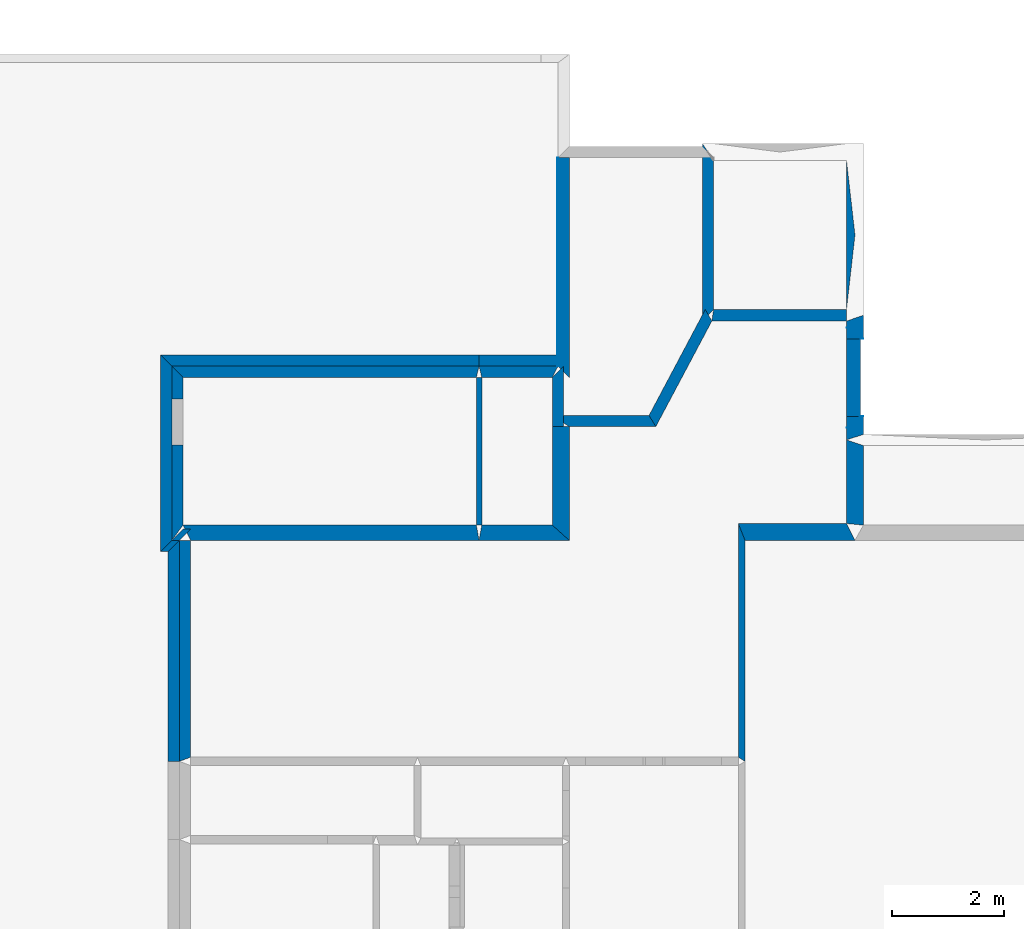
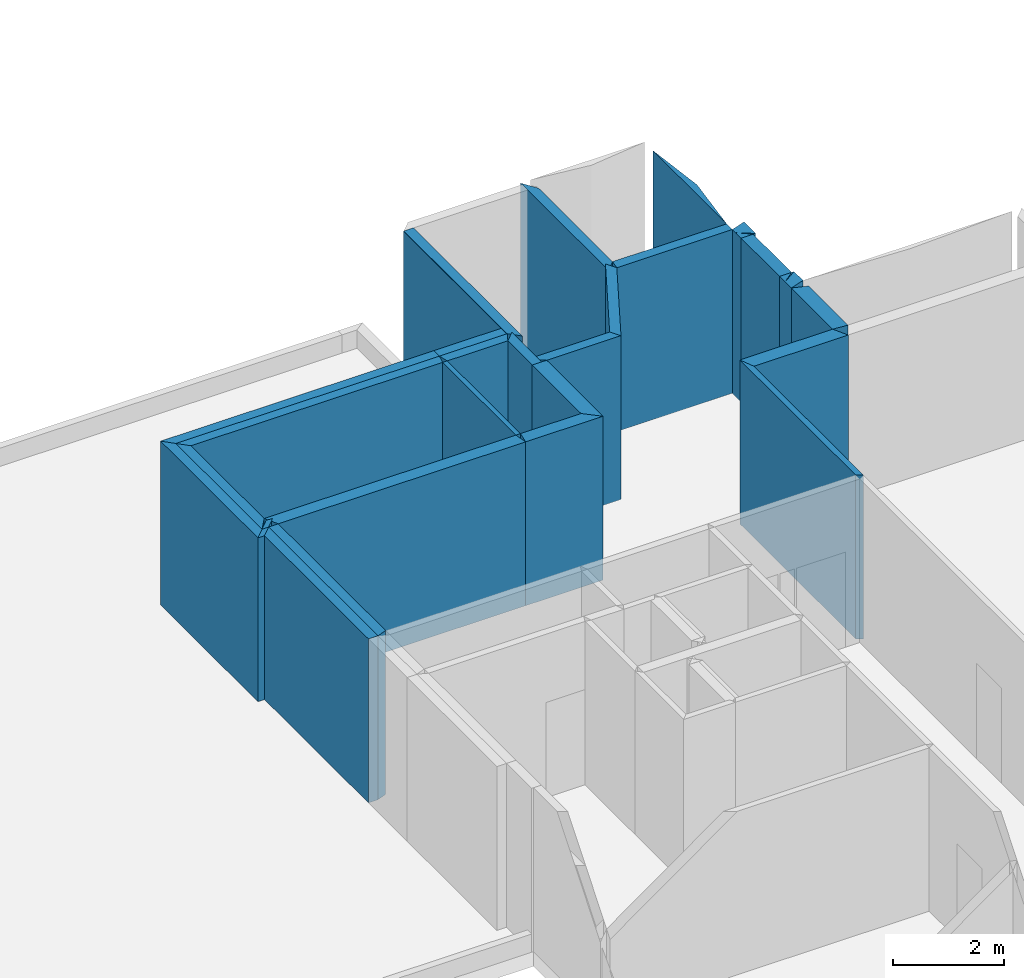
# One storey, part 4 of 72: 30 walls, 1 opening.
"""IFC2X3 building model written with IfcOpenShell, lengths in metres."""

from ifc_helpers import new_model, entity, si_unit, converted_unit, derived_unit, frame, origin_with_axes, place, context, project, spatial, polyline, outline, extrude, material, layer, layer_set, layer_usage, element, save


model = new_model("IFC2X3")

# Units and contexts
context_of_model_1 = context(None, 3, world=origin_with_axes())
context_of_model_2 = context(None, 3, world=origin_with_axes())
context_of_model_3 = context(None, 2, world=origin_with_axes())
context_of_model_4 = context(None, 3, world=origin_with_axes())
ifc_project = project(units=[si_unit("LENGTHUNIT", "METRE"), si_unit("AREAUNIT", "SQUARE_METRE"), si_unit("ELECTRICCURRENTUNIT", "AMPERE"), si_unit("ELECTRICVOLTAGEUNIT", "VOLT"), si_unit("ELECTRICRESISTANCEUNIT", "OHM"), si_unit("POWERUNIT", "WATT"), si_unit("MASSUNIT", "GRAM"), si_unit("SOLIDANGLEUNIT", "STERADIAN"), si_unit("THERMODYNAMICTEMPERATUREUNIT", "KELVIN"), si_unit("PRESSUREUNIT", "PASCAL"), si_unit("LUMINOUSFLUXUNIT", "LUMEN"), si_unit("ILLUMINANCEUNIT", "LUX"), si_unit("FREQUENCYUNIT", "HERTZ"), si_unit("VOLUMEUNIT", "CUBIC_METRE"), si_unit("TIMEUNIT", "SECOND"), derived_unit("VOLUMETRICFLOWRATEUNIT", [(si_unit("TIMEUNIT", "SECOND"), -1), (si_unit("VOLUMEUNIT", "CUBIC_METRE"), 1)]), derived_unit("THERMALTRANSMITTANCEUNIT", [(si_unit("AREAUNIT", "SQUARE_METRE"), -1), (si_unit("THERMODYNAMICTEMPERATUREUNIT", "KELVIN"), -1), (si_unit("POWERUNIT", "WATT"), 1)]), converted_unit("PLANEANGLEUNIT", "DEGREE", entity("IfcPlaneAngleMeasure", 57.29577951308232), si_unit("PLANEANGLEUNIT", "RADIAN"), dimensions=[0, 0, 0, 0, 0, 0, 0])], contexts=[context_of_model_1, context_of_model_2, context_of_model_3, context_of_model_4])

# Site, building, storey
site = spatial("IfcSite", under=ifc_project, CompositionType="ELEMENT")
building_placement = place(None, origin_with_axes())
building = spatial("IfcBuilding", under=site, at=building_placement, Name="200", CompositionType="ELEMENT")
storey_placement = place(building_placement, frame((0.0, 0.0, 15.68000030517578), z_axis=(0.0, 0.0, 1.0), x_axis=(1.0, 0.0, 0.0)))
storey = spatial("IfcBuildingStorey", under=building, at=storey_placement, Name="3.etasje", CompositionType="ELEMENT", Elevation=15.68000030517578)

# Walls
ifc_material_1 = material(Name="Layer-YV04 20 cm")
ifc_layer_1 = layer(ifc_material_1, 0.2000000029802322, ventilated=False)
ifc_layer_set_1 = layer_set([ifc_layer_1])
ifc_layer_usage_1 = layer_usage(ifc_layer_set_1, "AXIS2", "POSITIVE", 0.0)
wall_1_placement = place(storey_placement, frame((5.74828577041626, 48.1895751953125, 0.0), z_axis=(0.0, 0.0, 1.0), x_axis=(-1.0, -8.742277657347586e-08, 0.0)))
element("IfcWallStandardCase", 1, at=wall_1_placement, inside=storey, material=ifc_layer_usage_1, Name="YV04 20 cm", context=context_of_model_1, shape_type="SweptSolid", body=[
    extrude(outline(polyline([(0.0, 0.0), (0.05150032043457052, 0.0), (0.3015003204345584, 0.2000007629394664), (0.3015003204345584, 0.2000007629394664), (0.0, 0.0)])), frame((0.0, 0.0, 0.0), z_axis=(0.0, 0.0, 1.0), x_axis=(0.9999999999999961, -8.742284065731986e-08, 0.0)), (0.0, 0.0, 1.0), 3.6),
])
wall_2_placement = place(storey_placement, frame((5.69678544998169, 49.57145309448242, 0.0), z_axis=(0.0, 0.0, 1.0), x_axis=(1.0, 0.0, 0.0)))
element("IfcWallStandardCase", 2, at=wall_2_placement, inside=storey, material=ifc_layer_usage_1, Name="YV04 20 cm", context=context_of_model_1, shape_type="SweptSolid", body=[
    extrude(outline(polyline([(0.0, 0.0), (0.05150032043457031, 0.0), (-0.25, 0.2000007629394531), (-0.25, 0.2000007629394531), (0.0, 0.0)])), origin_with_axes(), (0.0, 0.0, 1.0), 3.6),
])
ifc_material_2 = material(Name="Layer-YV1 20.0cm")
ifc_layer_2 = layer(ifc_material_2, 0.2000045776367188, ventilated=False)
ifc_layer_set_2 = layer_set([ifc_layer_2])
ifc_layer_usage_2 = layer_usage(ifc_layer_set_2, "AXIS2", "POSITIVE", 0.0)
wall_3_placement = place(storey_placement, frame((0.3039190173149109, 52.80139923095703, 0.0), z_axis=(0.0, 0.0, 1.0), x_axis=(-4.371138828673793e-08, -1.0, 0.0)))
element("IfcWallStandardCase", 3, at=wall_3_placement, inside=storey, material=ifc_layer_usage_2, Name="YV1 20.0cm", context=context_of_model_1, shape_type="SweptSolid", body=[
    extrude(outline(polyline([(0.0, 0.0), (3.718673706054692, 0.0), (3.918674468994146, 0.199999988079071), (1.241773028289315e-15, 0.199999988079071), (0.0, 0.0)])), frame((0.0, 0.0, 0.0), z_axis=(0.0, 0.0, 1.0), x_axis=(0.999999999999999, 4.371138999557761e-08, 0.0)), (0.0, 0.0, 1.0), 3.6),
])
wall_4_placement = place(storey_placement, frame((-6.582164287567139, 45.9775390625, 0.0), z_axis=(0.0, 0.0, 1.0), x_axis=(1.0, 0.0, 0.0)))
element("IfcWallStandardCase", 4, at=wall_4_placement, inside=storey, material=ifc_layer_usage_2, Name="YV1 20.0cm", context=context_of_model_1, shape_type="SweptSolid", body=[
    extrude(outline(polyline([(0.0, 0.0), (0.1362824440002441, 0.0), (0.3362822532653809, 0.2000007629394531), (0.1999998092651367, 0.2000007629394531), (0.0, 0.0)])), origin_with_axes(), (0.0, 0.0, 1.0), 3.6),
])
wall_5_placement = place(storey_placement, frame((-6.445881843566895, 42.03710174560547, 0.0), z_axis=(0.0, 0.0, 1.0), x_axis=(-4.371138828673793e-08, 1.0, 0.0)))
element("IfcWallStandardCase", 5, at=wall_5_placement, inside=storey, material=ifc_layer_usage_2, Name="YV1 20.0cm", context=context_of_model_1, shape_type="SweptSolid", body=[
    extrude(outline(polyline([(0.0, 0.0), (3.940437316894536, -2.646977960169689e-23), (3.740436553955082, 0.1999998092651374), (-5.265606405882878e-16, 0.1999998092651369), (0.0, 0.0)])), frame((0.0, 0.0, 0.0), z_axis=(0.0, 0.0, 1.0), x_axis=(0.999999999999999, -4.37113899734069e-08, 0.0)), (0.0, 0.0, 1.0), 3.6),
])
wall_6_placement = place(storey_placement, frame((-6.445881843566895, 45.9775390625, 0.0), z_axis=(0.0, 0.0, 1.0), x_axis=(-1.0, -8.742277657347586e-08, 0.0)))
element("IfcWallStandardCase", 6, at=wall_6_placement, inside=storey, material=ifc_layer_usage_2, Name="YV1 20.0cm", context=context_of_model_1, shape_type="SweptSolid", body=[
    extrude(outline(polyline([(0.0, 0.0), (0.1362824440002438, 0.0), (0.3362822532653824, 0.2000007629394529), (0.1999998092651386, 0.2000007629394529), (0.0, 0.0)])), frame((0.0, 0.0, 0.0), z_axis=(0.0, 0.0, 1.0), x_axis=(0.9999999999999961, -8.742276992526926e-08, 0.0)), (0.0, 0.0, 1.0), 3.6),
])
wall_7_placement = place(storey_placement, frame((-6.582164287567139, 45.9775390625, 0.0), z_axis=(0.0, 0.0, 1.0), x_axis=(-4.371138828673793e-08, 1.0, 0.0)))
element("IfcWallStandardCase", 7, at=wall_7_placement, inside=storey, material=ifc_layer_usage_2, Name="YV1 20.0cm", context=context_of_model_1, shape_type="SweptSolid", body=[
    extrude(outline(polyline([(0.0, 0.0), (3.105186462402339, 0.0), (3.305187225341792, 0.1999998092651355), (-0.2000007629394538, 0.1999998092651364), (0.0, 0.0)])), frame((0.0, 0.0, 0.0), z_axis=(0.0, 0.0, 1.0), x_axis=(0.9999999999999991, -4.371138979655161e-08, 0.0)), (0.0, 0.0, 1.0), 3.6),
])
wall_8_placement = place(storey_placement, frame((-6.582164287567139, 49.08272552490234, 0.0), z_axis=(0.0, 0.0, 1.0), x_axis=(1.0, 0.0, 0.0)))
element("IfcWallStandardCase", 8, at=wall_8_placement, inside=storey, material=ifc_layer_usage_2, Name="YV1 20.0cm", context=context_of_model_1, shape_type="SweptSolid", body=[
    extrude(outline(polyline([(0.0, 0.0), (5.477957963943481, 0.0), (5.477957963943481, 0.2000007629394531), (-0.1999998092651367, 0.2000007629394531), (0.0, 0.0)])), origin_with_axes(), (0.0, 0.0, 1.0), 3.6),
])
wall_9_placement = place(storey_placement, frame((-1.104206323623657, 49.08272552490234, 0.0), z_axis=(0.0, 0.0, 1.0), x_axis=(1.0, 0.0, 0.0)))
element("IfcWallStandardCase", 9, at=wall_9_placement, inside=storey, material=ifc_layer_usage_2, Name="YV1 20.0cm", context=context_of_model_1, shape_type="SweptSolid", body=[
    extrude(outline(polyline([(0.0, 0.0), (1.408125340938568, 0.0), (1.398125410079956, 0.2000007629394531), (0.0, 0.2000007629394531), (0.0, 0.0)])), origin_with_axes(), (0.0, 0.0, 1.0), 3.6),
])
ifc_material_3 = material(Name="Layer-YV1 20.0cm")
ifc_layer_3 = layer(ifc_material_3, 0.01, ventilated=False)
ifc_layer_set_3 = layer_set([ifc_layer_3])
ifc_layer_usage_3 = layer_usage(ifc_layer_set_3, "AXIS2", "POSITIVE", 0.0)
wall_10_placement = place(storey_placement, frame((0.3039190173149109, 49.08272552490234, 0.0), z_axis=(0.0, 0.0, 1.0), x_axis=(-4.371138828673793e-08, 1.0, 0.0)))
element("IfcWallStandardCase", 10, at=wall_10_placement, inside=storey, material=ifc_layer_usage_3, Name="YV1 20.0cm", context=context_of_model_1, shape_type="SweptSolid", body=[
    extrude(outline(polyline([(0.0, 0.0), (3.718673706054692, 0.0), (3.718673706054697, 0.009999990463256848), (5.302520779185142e-15, 0.009999990463256848), (0.0, 0.0)])), frame((0.0, 0.0, 0.0), z_axis=(0.0, 0.0, 1.0), x_axis=(0.999999999999999, -4.371138999557761e-08, 0.0)), (0.0, 0.0, 1.0), 3.6),
])
ifc_material_4 = material()
ifc_layer_4 = layer(ifc_material_4, 0.3015022277832031, ventilated=False)
ifc_layer_set_4 = layer_set([ifc_layer_4])
ifc_layer_usage_4 = layer_usage(ifc_layer_set_4, "AXIS2", "POSITIVE", 0.0)
wall_11_placement = place(storey_placement, frame((5.44678544998169, 47.76724243164063, 0.0), z_axis=(0.0, 0.0, 1.0), x_axis=(-4.371138828673793e-08, -1.0, 0.0)))
element("IfcWallStandardCase", 11, at=wall_11_placement, inside=storey, material=ifc_layer_usage_4, context=context_of_model_1, shape_type="SweptSolid", body=[
    extrude(outline(polyline([(0.0, 0.0), (1.490291595458986, 0.0), (1.51835632324219, 0.30150032043457), (0.09999847412109447, 0.3015003204345699), (0.0, 0.0)])), frame((0.0, 0.0, 0.0), z_axis=(0.0, 0.0, 1.0), x_axis=(0.999999999999999, 4.371138990310161e-08, 0.0)), (0.0, 0.0, 1.0), 3.6),
])
ifc_material_5 = material()
ifc_layer_5 = layer(ifc_material_5, 0.2713546752929688, ventilated=False)
ifc_layer_set_5 = layer_set([ifc_layer_5])
ifc_layer_usage_5 = layer_usage(ifc_layer_set_5, "AXIS2", "POSITIVE", 0.0)
wall_12_placement = place(storey_placement, frame((-1.104206323623657, 45.9775390625, 0.0), z_axis=(0.0, 0.0, 1.0), x_axis=(1.0, 0.0, 0.0)))
element("IfcWallStandardCase", 12, at=wall_12_placement, inside=storey, material=ifc_layer_usage_5, context=context_of_model_1, shape_type="SweptSolid", body=[
    extrude(outline(polyline([(0.0, 0.0), (1.607924401760101, 0.0), (1.306625828146935, 0.2713470458984375), (0.04805123805999756, 0.2713470458984375), (0.0, 0.0)])), origin_with_axes(), (0.0, 0.0, 1.0), 3.6),
])
ifc_material_6 = material()
ifc_layer_6 = layer(ifc_material_6, 0.3006705939769745, ventilated=False)
ifc_layer_set_6 = layer_set([ifc_layer_6])
ifc_layer_usage_6 = layer_usage(ifc_layer_set_6, "AXIS2", "POSITIVE", 0.0)
wall_13_placement = place(storey_placement, frame((0.5037180781364441, 45.9775390625, 0.0), z_axis=(0.0, 0.0, 1.0), x_axis=(-4.371138828673793e-08, 1.0, 0.0)))
element("IfcWallStandardCase", 13, at=wall_13_placement, inside=storey, material=ifc_layer_usage_6, context=context_of_model_1, shape_type="SweptSolid", body=[
    extrude(outline(polyline([(0.0, 0.0), (2.027553558349605, 0.0), (2.027553558349605, 0.3012985736131668), (0.2713470458984309, 0.3012985736131667), (0.0, 0.0)])), frame((0.0, 0.0, 0.0), z_axis=(0.0, 0.0, 1.0), x_axis=(0.9999999999999989, -4.371139001691056e-08, 0.0)), (0.0, 0.0, 1.0), 3.6),
])
ifc_material_7 = material()
ifc_layer_7 = layer(ifc_material_7, 0.2000000029802322, ventilated=False)
ifc_layer_set_7 = layer_set([ifc_layer_7])
ifc_layer_usage_7 = layer_usage(ifc_layer_set_7, "AXIS2", "POSITIVE", 0.0)
wall_14_placement = place(storey_placement, frame((0.4024195075035095, 48.00509262084961, 0.0), z_axis=(0.0, 0.0, 1.0), x_axis=(-4.371138828673793e-08, 1.0, 0.0)))
element("IfcWallStandardCase", 14, at=wall_14_placement, inside=storey, material=ifc_layer_usage_7, context=context_of_model_1, shape_type="SweptSolid", body=[
    extrude(outline(polyline([(0.0, 0.0), (1.077632904052736, 0.0), (0.8776321411132804, 0.2000000029802323), (-1.894026830140747e-15, 0.2000000029802323), (0.0, 0.0)])), frame((0.0, 0.0, 0.0), z_axis=(0.0, 0.0, 1.0), x_axis=(0.999999999999999, -4.371139000009425e-08, 0.0)), (0.0, 0.0, 1.0), 3.6),
])
wall_15_placement = place(storey_placement, frame((0.3039190173149109, 49.08272552490234, 0.0), z_axis=(0.0, 0.0, 1.0), x_axis=(-1.0, -8.742277657347586e-08, 0.0)))
element("IfcWallStandardCase", 15, at=wall_15_placement, inside=storey, material=ifc_layer_usage_7, context=context_of_model_1, shape_type="SweptSolid", body=[
    extrude(outline(polyline([(0.0, 0.0), (1.408125340938568, 2.646977960169689e-23), (1.360074102878571, 0.2000007629394524), (0.1014995127916335, 0.2000007629394522), (0.0, 0.0)])), frame((0.0, 0.0, 0.0), z_axis=(0.0, 0.0, 1.0), x_axis=(0.9999999999999962, -8.742278036534271e-08, 0.0)), (0.0, 0.0, 1.0), 3.6),
])
ifc_material_8 = material()
ifc_layer_8 = layer(ifc_material_8, 0.09644508361816406, ventilated=False)
ifc_layer_set_8 = layer_set([ifc_layer_8])
ifc_layer_usage_8 = layer_usage(ifc_layer_set_8, "AXIS2", "POSITIVE", 0.0)
wall_16_placement = place(storey_placement, frame((-1.152257680892944, 48.88272476196289, 0.0), z_axis=(0.0, 0.0, 1.0), x_axis=(-4.371138828673793e-08, -1.0, 0.0)))
element("IfcWallStandardCase", 16, at=wall_16_placement, inside=storey, material=ifc_layer_usage_8, context=context_of_model_1, shape_type="SweptSolid", body=[
    extrude(outline(polyline([(0.0, 0.0), (2.633838653564456, 1.323488980084844e-23), (2.633838653564456, 0.09610259532928478), (-3.691222519693135e-16, 0.09610259532928478), (0.0, 0.0)])), frame((0.0, 0.0, 0.0), z_axis=(0.0, 0.0, 1.0), x_axis=(0.999999999999999, 4.371138998160735e-08, 0.0)), (0.0, 0.0, 1.0), 3.6),
])
ifc_material_9 = material()
ifc_layer_9 = layer(ifc_material_9, 0.2712287902832031, ventilated=False)
ifc_layer_set_9 = layer_set([ifc_layer_9])
ifc_layer_usage_9 = layer_usage(ifc_layer_set_9, "AXIS2", "POSITIVE", 0.0)
wall_17_placement = place(storey_placement, frame((-6.245882034301758, 45.9775390625, 0.0), z_axis=(0.0, 0.0, 1.0), x_axis=(1.0, 0.0, 0.0)))
element("IfcWallStandardCase", 17, at=wall_17_placement, inside=storey, material=ifc_layer_usage_9, context=context_of_model_1, shape_type="SweptSolid", body=[
    extrude(outline(polyline([(0.0, 0.0), (5.141675710678101, 0.0), (5.093624353408814, 0.2713470458984375), (-0.1362819671630859, 0.2713470458984375), (0.0, 0.0)])), origin_with_axes(), (0.0, 0.0, 1.0), 3.6),
])
wall_18_placement = place(storey_placement, frame((-1.104206323623657, 49.08272552490234, 0.0), z_axis=(0.0, 0.0, 1.0), x_axis=(-1.0, -8.742277657347586e-08, 0.0)))
element("IfcWallStandardCase", 18, at=wall_18_placement, inside=storey, material=ifc_layer_usage_7, context=context_of_model_1, shape_type="SweptSolid", body=[
    extrude(outline(polyline([(0.0, 0.0), (5.477957963943481, 0.0), (5.277957677841187, 0.2000007629394538), (0.04805135726928699, 0.2000007629394517), (0.0, 0.0)])), frame((0.0, 0.0, 0.0), z_axis=(0.0, 0.0, 1.0), x_axis=(0.9999999999999961, -8.74227801553122e-08, 0.0)), (0.0, 0.0, 1.0), 3.6),
])

# Wall, opening
wall_19_placement = place(storey_placement, frame((-6.582164287567139, 49.08272552490234, 0.0), z_axis=(0.0, 0.0, 1.0), x_axis=(-4.371138828673793e-08, -1.0, 0.0)))
wall_19 = element("IfcWallStandardCase", 19, at=wall_19_placement, inside=storey, material=ifc_layer_usage_7, context=context_of_model_1, shape_type="SweptSolid", body=[
    extrude(outline(polyline([(0.0, 0.0), (3.105186462402339, 0.0), (2.833839416503909, 0.200000286102295), (0.2000007629394533, 0.2000002861022947), (0.0, 0.0)])), frame((0.0, 0.0, 0.0), z_axis=(0.0, 0.0, 1.0), x_axis=(0.9999999999999991, 4.371138979655161e-08, 0.0)), (0.0, 0.0, 1.0), 3.6),
])
opening_placement = place(wall_19_placement, frame((0.5870971592264596, 0.2000003117651277, 0.0), z_axis=(0.0, 0.0, 1.0), x_axis=(1.0, 0.0, 0.0)))
element("IfcOpeningElement", 20, at=opening_placement, cuts=wall_19, context=context_of_model_1, shape_type="SweptSolid", body=[
    extrude(outline(polyline([(0.0, 0.0), (2.099999904632568, 0.0), (2.099999904632568, 0.8140487670898446), (0.0, 0.8140487670898446), (0.0, 0.0)])), frame((0.0, 0.0, 0.0), z_axis=(-4.371138989369828e-08, 0.999999999999999, 0.0), x_axis=(0.0, 0.0, 1.0)), (0.0, -4.371138989369829e-08, -0.9999999999999992), 0.2000000029802322),
])

# Walls
ifc_material_10 = material()
ifc_layer_10 = layer(ifc_material_10, 0.2991085052490234, ventilated=False)
ifc_layer_set_10 = layer_set([ifc_layer_10])
ifc_layer_usage_10 = layer_usage(ifc_layer_set_10, "AXIS2", "POSITIVE", 0.0)
wall_20_placement = place(storey_placement, frame((5.44678544998169, 46.27695083618164, 0.0), z_axis=(0.0, 0.0, 1.0), x_axis=(-1.0, -8.742277657347586e-08, 0.0)))
element("IfcWallStandardCase", 21, at=wall_20_placement, inside=storey, material=ifc_layer_usage_10, context=context_of_model_1, shape_type="SweptSolid", body=[
    extrude(outline(polyline([(0.0, 0.0), (1.929569244384766, 0.0), (1.80897068977356, 0.2994117736816352), (-0.1507501602172845, 0.2994117736816339), (0.0, 0.0)])), frame((0.0, 0.0, 0.0), z_axis=(0.0, 0.0, 1.0), x_axis=(0.9999999999999962, -8.74227810346714e-08, 0.0)), (0.0, 0.0, 1.0), 3.6),
])
ifc_material_11 = material()
ifc_layer_11 = layer(ifc_material_11, 0.1205999851226807, ventilated=False)
ifc_layer_set_11 = layer_set([ifc_layer_11])
ifc_layer_usage_11 = layer_usage(ifc_layer_set_11, "AXIS2", "POSITIVE", 0.0)
wall_21_placement = place(storey_placement, frame((3.517216205596924, 46.27695083618164, 0.0), z_axis=(0.0, 0.0, 1.0), x_axis=(-4.371138828673793e-08, -1.0, 0.0)))
element("IfcWallStandardCase", 22, at=wall_21_placement, inside=storey, material=ifc_layer_usage_11, context=context_of_model_1, shape_type="SweptSolid", body=[
    extrude(outline(polyline([(0.0, 0.0), (4.164474487304684, -2.646977960169689e-23), (4.239849090576175, 0.1205985546112059), (0.2994117736816406, 0.1205985546112064), (0.0, 0.0)])), frame((0.0, 0.0, 0.0), z_axis=(0.0, 0.0, 1.0), x_axis=(0.9999999999999991, 4.371139010007038e-08, 0.0)), (0.0, 0.0, 1.0), 3.6),
])
ifc_material_12 = material(Name="Layer-Yttervegg 30.0cm")
ifc_layer_12 = layer(ifc_material_12, 0.3015003204345703, ventilated=False)
ifc_layer_set_12 = layer_set([ifc_layer_12], Name="ML-Yttervegg 30.0cm - 0.302")
ifc_layer_usage_12 = layer_usage(ifc_layer_set_12, "AXIS2", "POSITIVE", 0.0)
wall_22_placement = place(storey_placement, frame((5.74828577041626, 47.86724472045898, 0.0), z_axis=(0.0, 0.0, 1.0), x_axis=(-4.371138828673793e-08, 1.0, 0.0)))
element("IfcWallStandardCase", 23, at=wall_22_placement, inside=storey, material=ifc_layer_usage_12, Name="Yttervegg 30.0cm", context=context_of_model_1, shape_type="SweptSolid", body=[
    extrude(outline(polyline([(0.0, 0.0), (0.3223304748535159, 1.654361225106055e-24), (0.3223304748535149, 0.3015003204345705), (-0.1000022888183605, 0.3015003204345708), (0.0, 0.0)])), frame((0.0, 0.0, 0.0), z_axis=(0.0, 0.0, 1.0), x_axis=(0.9999999999999991, -4.371139142913011e-08, 0.0)), (0.0, 0.0, 1.0), 3.6),
])
ifc_material_13 = material(Name="Layer-Yttervegg 25.0cm")
ifc_layer_13 = layer(ifc_material_13, 0.25, ventilated=False)
ifc_layer_set_13 = layer_set([ifc_layer_13], Name="ML-Yttervegg 25.0cm - 0.250")
ifc_layer_usage_13 = layer_usage(ifc_layer_set_13, "AXIS2", "POSITIVE", 0.0)
wall_23_placement = place(storey_placement, frame((5.69678544998169, 48.1895751953125, 0.0), z_axis=(0.0, 0.0, 1.0), x_axis=(-4.371138828673793e-08, 1.0, 0.0)))
element("IfcWallStandardCase", 24, at=wall_23_placement, inside=storey, material=ifc_layer_usage_13, Name="Yttervegg 25.0cm", context=context_of_model_1, shape_type="SweptSolid", body=[
    extrude(outline(polyline([(0.0, 0.0), (1.381877899169923, 0.0), (1.381877899169925, 0.2500000000000002), (1.356431656429283e-15, 0.2500000000000002), (0.0, 0.0)])), frame((0.0, 0.0, 0.0), z_axis=(0.0, 0.0, 1.0), x_axis=(0.999999999999999, -4.371138996643862e-08, 0.0)), (0.0, 0.0, 1.0), 3.6),
])
wall_24_placement = place(storey_placement, frame((5.74828577041626, 49.57145309448242, 0.0), z_axis=(0.0, 0.0, 1.0), x_axis=(-4.371138828673793e-08, 1.0, 0.0)))
element("IfcWallStandardCase", 25, at=wall_24_placement, inside=storey, material=ifc_layer_usage_12, Name="Yttervegg 30.0cm", context=context_of_model_1, shape_type="SweptSolid", body=[
    extrude(outline(polyline([(0.0, 0.0), (0.4189567565917972, 0.0), (0.3163185119628904, 0.3015003204345712), (-5.717637962437936e-16, 0.3015003204345705), (0.0, 0.0)])), frame((0.0, 0.0, 0.0), z_axis=(0.0, 0.0, 1.0), x_axis=(0.9999999999999991, -4.371138976460105e-08, 0.0)), (0.0, 0.0, 1.0), 3.6),
])
ifc_material_14 = material()
ifc_layer_14 = layer(ifc_material_14, 0.2052726745605469, ventilated=False)
ifc_layer_set_14 = layer_set([ifc_layer_14])
ifc_layer_usage_14 = layer_usage(ifc_layer_set_14, "AXIS2", "POSITIVE", 0.0)
wall_25_placement = place(storey_placement, frame((5.446785926818848, 50.09304428100586, 0.0), z_axis=(0.0, 0.0, 1.0), x_axis=(-1.0, -8.742277657347586e-08, 0.0)))
element("IfcWallStandardCase", 26, at=wall_25_placement, inside=storey, material=ifc_layer_usage_14, context=context_of_model_1, shape_type="SweptSolid", body=[
    extrude(outline(polyline([(0.0, 0.0), (2.369800806045533, 2.646977960169689e-23), (2.400358438491821, 0.2052726745605534), (4.768371580748772e-07, 0.2052726745605467), (0.0, 0.0)])), frame((0.0, 0.0, 0.0), z_axis=(0.0, 0.0, 1.0), x_axis=(0.9999999999999962, -8.742278219559525e-08, 0.0)), (0.0, 0.0, 1.0), 3.6),
])
wall_26_placement = place(storey_placement, frame((2.928991556167603, 50.09304428100586, 0.0), z_axis=(0.0, 0.0, 1.0), x_axis=(-0.4690557718276978, -0.8831685781478882, 0.0)))
element("IfcWallStandardCase", 27, at=wall_26_placement, inside=storey, material=ifc_layer_usage_7, context=context_of_model_1, shape_type="SweptSolid", body=[
    extrude(outline(polyline([(0.0, 0.0), (2.137701675218338, 0.0), (2.257938932737248, 0.1999996721542576), (0.1262063708188532, 0.200000052620307), (0.0, 0.0)])), frame((0.0, 0.0, 0.0), z_axis=(0.0, 0.0, 1.0), x_axis=(1.0, 8.488871709240024e-09, 0.0)), (0.0, 0.0, 1.0), 3.6),
])
wall_27_placement = place(storey_placement, frame((1.926290035247803, 48.20509338378906, 0.0), z_axis=(0.0, 0.0, 1.0), x_axis=(-1.0, -8.742277657347586e-08, 0.0)))
element("IfcWallStandardCase", 28, at=wall_27_placement, inside=storey, material=ifc_layer_usage_7, context=context_of_model_1, shape_type="SweptSolid", body=[
    extrude(outline(polyline([(0.0, 0.0), (1.723870515823364, 0.0), (1.422571957111359, 0.2000007629394555), (-0.1202356815338138, 0.2000007629394593), (0.0, 0.0)])), frame((0.0, 0.0, 0.0), z_axis=(0.0, 0.0, 1.0), x_axis=(0.9999999999999962, -8.742278004213978e-08, 0.0)), (0.0, 0.0, 1.0), 3.6),
])
wall_28_placement = place(storey_placement, frame((-6.445881843566895, 45.9775390625, 0.0), z_axis=(0.0, 0.0, 1.0), x_axis=(-4.371138828673793e-08, -1.0, 0.0)))
element("IfcWallStandardCase", 29, at=wall_28_placement, inside=storey, material=ifc_layer_usage_7, context=context_of_model_1, shape_type="SweptSolid", body=[
    extrude(outline(polyline([(0.0, 0.0), (3.940437316894536, 2.646977960169689e-23), (3.865062713623052, 0.1999998092651376), (5.265606405882878e-16, 0.1999998092651369), (0.0, 0.0)])), frame((0.0, 0.0, 0.0), z_axis=(0.0, 0.0, 1.0), x_axis=(0.999999999999999, 4.37113899734069e-08, 0.0)), (0.0, 0.0, 1.0), 3.6),
])
ifc_material_15 = material(Name="Layer-YV04 20 cm")
ifc_layer_15 = layer(ifc_material_15, 0.3014998435974121, ventilated=False)
ifc_layer_set_15 = layer_set([ifc_layer_15])
ifc_layer_usage_15 = layer_usage(ifc_layer_set_15, "AXIS2", "POSITIVE", 0.0)
wall_29_placement = place(storey_placement, frame((5.446785926818848, 50.09304428100586, 0.0), z_axis=(0.0, 0.0, 1.0), x_axis=(-4.371138828673793e-08, 1.0, 0.0)))
element("IfcWallStandardCase", 30, at=wall_29_placement, inside=storey, material=ifc_layer_usage_15, Name="YV04 20 cm", context=context_of_model_1, shape_type="SweptSolid", body=[
    extrude(outline(polyline([(0.0, 0.0), (2.657112121582034, 1.323488980084844e-23), (1.127326978949328e-15, 0.3014998435974124), (2.657112121582035, 0.3014998435974124), (0.0, 0.0)])), frame((0.0, 0.0, 0.0), z_axis=(0.0, 0.0, -1.0), x_axis=(0.999999999999999, -4.371139003821972e-08, 0.0)), (0.0, 0.0, -1.0), 3.6),
])
wall_30_placement = place(storey_placement, frame((2.8769850730896, 53.05165863037109, 0.0), z_axis=(0.0, 0.0, 1.0), x_axis=(-4.371138828673793e-08, -1.0, 0.0)))
element("IfcWallStandardCase", 31, at=wall_30_placement, inside=storey, material=ifc_layer_usage_7, context=context_of_model_1, shape_type="SweptSolid", body=[
    extrude(outline(polyline([(0.0, 0.0), (3.163887023925785, 0.0), (2.958614349365241, 0.2000000476837154), (0.3015022277832073, 0.2000000476837159), (0.0, 0.0)])), frame((0.0, 0.0, 0.0), z_axis=(0.0, 0.0, 1.0), x_axis=(0.999999999999999, 4.371139005690506e-08, 0.0)), (0.0, 0.0, 1.0), 3.6),
])

save(model, "model.ifc")
